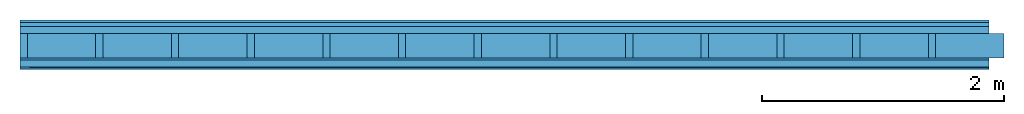
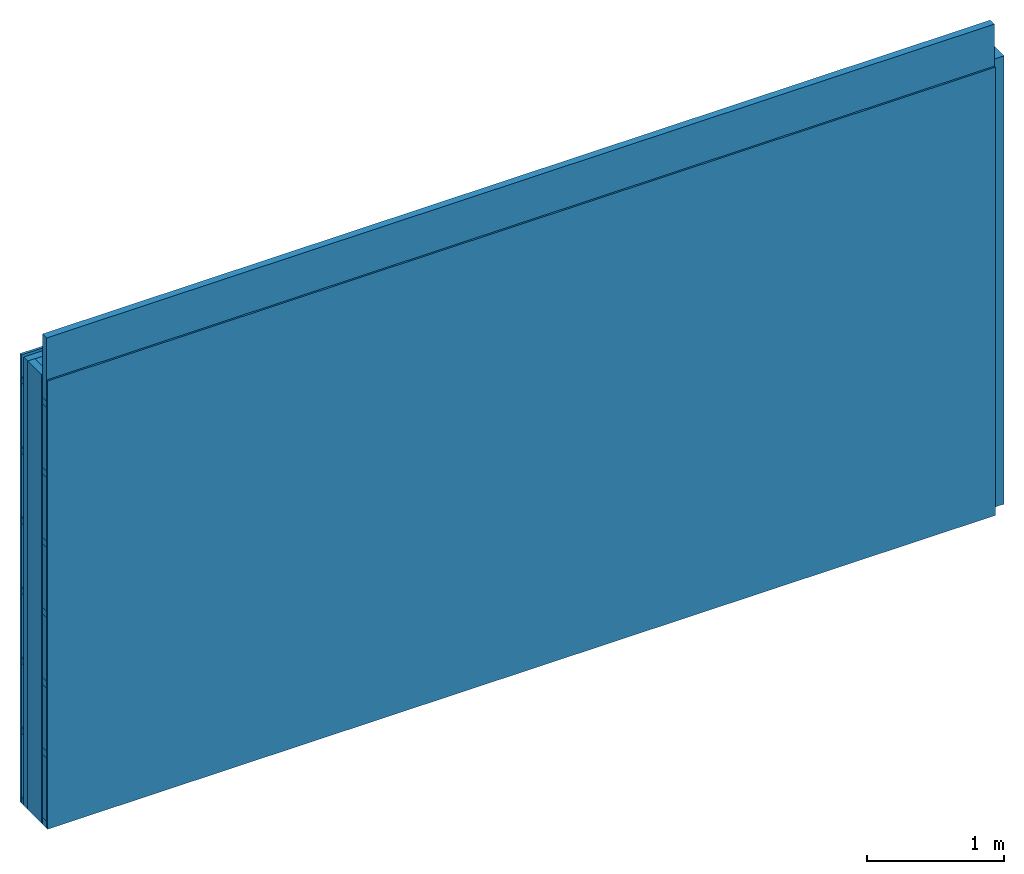
# One storey: 5 members, 4 plates, 1 element without a shape of its own.
"""IFC4 building model written with IfcOpenShell, lengths in metres."""

from ifc_helpers import new_model, si_unit, derived_unit, direction, frame, frame_2d, origin, origin_with_axes, place, context, project, spatial, rectangle, extrude, material, layer, layer_set, type_object, element, aggregate, save


model = new_model("IFC4")

# Units and contexts
plan_context = context("Plan", 3, precision=1e-05, world=origin(), true_north=direction((0.0, 1.0)))
model_context = context("Model", 3, precision=1e-05, world=origin(), true_north=direction((0.0, 1.0)))
ifc_project = project(units=[si_unit("LENGTHUNIT", "METRE"), derived_unit("SOUNDPRESSUREUNIT", [(si_unit("PRESSUREUNIT", "PASCAL", prefix="MICRO"), 0)]), si_unit("ENERGYUNIT", "JOULE", prefix="MEGA"), si_unit("MASSUNIT", "GRAM", prefix="KILO"), derived_unit("THERMALTRANSMITTANCEUNIT", [(si_unit("POWERUNIT", "WATT"), 1), (si_unit("AREAUNIT", "SQUARE_METRE"), -1), (si_unit("THERMODYNAMICTEMPERATUREUNIT", "KELVIN"), -1)]), derived_unit("AREADENSITYUNIT", [(si_unit("MASSUNIT", "GRAM", prefix="KILO"), 1), (si_unit("AREAUNIT", "SQUARE_METRE"), -1)]), derived_unit("USERDEFINED", [(si_unit("ENERGYUNIT", "JOULE", prefix="MEGA"), 1), (si_unit("AREAUNIT", "SQUARE_METRE"), -1)])], contexts=[plan_context, model_context])

# Site, building, storey
site = spatial("IfcSite", under=ifc_project)
building_placement = place(None, origin())
building = spatial("IfcBuilding", under=site, at=building_placement)
storey_placement = place(building_placement, origin())
storey = spatial("IfcBuildingStorey", under=building, at=storey_placement)

# Wall, members, plates
ifc_material_1 = material(Name="Wood cladding horizontal, closed")
ifc_layer_1 = layer(ifc_material_1, 0.022, Name="Cover 1st layer")
ifc_layer_2 = layer(None, 0.03, Name="Battens / profiles (ventilation)")
ifc_material_2 = material(Category="10.009")
ifc_layer_3 = layer(ifc_material_2, 0.06, Name="outside 2nd layer")
ifc_material_3 = material(Name="of the art")
ifc_layer_4 = layer(ifc_material_3, 0.0, Name="Bond")
ifc_layer_5 = layer(None, 0.2, Name="Support")
ifc_layer_6 = layer(ifc_material_3, 0.0, Name="Bond")
ifc_material_4 = material(Category="07.013")
ifc_layer_7 = layer(ifc_material_4, 0.018, Name="1st layer")
ifc_layer_8 = layer(None, 0.06, Name="Battens / profiles")
ifc_material_5 = material(Category="03.007")
ifc_layer_9 = layer(ifc_material_5, 0.015, Name="Covering 1st layer")
ifc_material_6 = material(Name="Glued joints")
ifc_layer_10 = layer(ifc_material_6, 0.0, Name="Surface")
ifc_layer_set = layer_set([ifc_layer_1, ifc_layer_2, ifc_layer_3, ifc_layer_4, ifc_layer_5, ifc_layer_6, ifc_layer_7, ifc_layer_8, ifc_layer_9, ifc_layer_10])
wall_type = type_object("IfcWallType", Name="D0255", PredefinedType="NOTDEFINED", material=ifc_layer_set)
wall_placement = place(None, frame((0.0, 0.0, 0.0), z_axis=(0.0, -1.0, 0.0), x_axis=(1.0, 0.0, 0.0)))
wall = element("IfcWall", 1, at=wall_placement, inside=storey, type_object=wall_type, material=ifc_layer_set, Name="Wall #1")
ifc_material_7 = material()
member_1_placement = place(wall_placement, origin())
member_1 = element("IfcMember", 2, at=member_1_placement, material=ifc_material_7, Name="Battens / profiles (ventilation)", context=plan_context, shape_type="SweptSolid", body=[
    extrude(rectangle(XDim=0.05, YDim=0.03, at=frame_2d((0.025, 0.015), x_axis=(1.0, 0.0))), frame((0.0, 0.0, 0.022), z_axis=(1.0, 0.0, 0.0), x_axis=(0.0, 1.0, 0.0)), (0.0, 0.0, 1.0), 8.0),
    extrude(rectangle(XDim=0.05, YDim=0.03, at=frame_2d((0.025, 0.015), x_axis=(1.0, 0.0))), frame((0.0, 0.625, 0.022), z_axis=(1.0, 0.0, 0.0), x_axis=(0.0, 1.0, 0.0)), (0.0, 0.0, 1.0), 8.0),
    extrude(rectangle(XDim=0.05, YDim=0.03, at=frame_2d((0.025, 0.015), x_axis=(1.0, 0.0))), frame((0.0, 1.25, 0.022), z_axis=(1.0, 0.0, 0.0), x_axis=(0.0, 1.0, 0.0)), (0.0, 0.0, 1.0), 8.0),
    extrude(rectangle(XDim=0.05, YDim=0.03, at=frame_2d((0.025, 0.015), x_axis=(1.0, 0.0))), frame((0.0, 1.875, 0.022), z_axis=(1.0, 0.0, 0.0), x_axis=(0.0, 1.0, 0.0)), (0.0, 0.0, 1.0), 8.0),
    extrude(rectangle(XDim=0.05, YDim=0.03, at=frame_2d((0.025, 0.015), x_axis=(1.0, 0.0))), frame((0.0, 2.5, 0.022), z_axis=(1.0, 0.0, 0.0), x_axis=(0.0, 1.0, 0.0)), (0.0, 0.0, 1.0), 8.0),
    extrude(rectangle(XDim=0.05, YDim=0.03, at=frame_2d((0.025, 0.015), x_axis=(1.0, 0.0))), frame((0.0, 3.125, 0.022), z_axis=(1.0, 0.0, 0.0), x_axis=(0.0, 1.0, 0.0)), (0.0, 0.0, 1.0), 8.0),
    extrude(rectangle(XDim=0.05, YDim=0.03, at=frame_2d((0.025, 0.015), x_axis=(1.0, 0.0))), frame((0.0, 3.75, 0.022), z_axis=(1.0, 0.0, 0.0), x_axis=(0.0, 1.0, 0.0)), (0.0, 0.0, 1.0), 8.0),
])
ifc_material_8 = material()
member_2_placement = place(wall_placement, origin())
member_2 = element("IfcMember", 3, at=member_2_placement, material=ifc_material_8, Name="Support", context=plan_context, shape_type="SweptSolid", body=[
    extrude(rectangle(XDim=0.06, YDim=0.2, at=frame_2d((0.03, 0.1), x_axis=(1.0, 0.0))), frame((0.0, 4.0, 0.112), z_axis=(0.0, -1.0, 0.0), x_axis=(1.0, 0.0, 0.0)), (0.0, 0.0, 1.0), 4.0),
    extrude(rectangle(XDim=0.06, YDim=0.2, at=frame_2d((0.03, 0.1), x_axis=(1.0, 0.0))), frame((0.625, 4.0, 0.112), z_axis=(0.0, -1.0, 0.0), x_axis=(1.0, 0.0, 0.0)), (0.0, 0.0, 1.0), 4.0),
    extrude(rectangle(XDim=0.06, YDim=0.2, at=frame_2d((0.03, 0.1), x_axis=(1.0, 0.0))), frame((1.25, 4.0, 0.112), z_axis=(0.0, -1.0, 0.0), x_axis=(1.0, 0.0, 0.0)), (0.0, 0.0, 1.0), 4.0),
    extrude(rectangle(XDim=0.06, YDim=0.2, at=frame_2d((0.03, 0.1), x_axis=(1.0, 0.0))), frame((1.875, 4.0, 0.112), z_axis=(0.0, -1.0, 0.0), x_axis=(1.0, 0.0, 0.0)), (0.0, 0.0, 1.0), 4.0),
    extrude(rectangle(XDim=0.06, YDim=0.2, at=frame_2d((0.03, 0.1), x_axis=(1.0, 0.0))), frame((2.5, 4.0, 0.112), z_axis=(0.0, -1.0, 0.0), x_axis=(1.0, 0.0, 0.0)), (0.0, 0.0, 1.0), 4.0),
    extrude(rectangle(XDim=0.06, YDim=0.2, at=frame_2d((0.03, 0.1), x_axis=(1.0, 0.0))), frame((3.125, 4.0, 0.112), z_axis=(0.0, -1.0, 0.0), x_axis=(1.0, 0.0, 0.0)), (0.0, 0.0, 1.0), 4.0),
    extrude(rectangle(XDim=0.06, YDim=0.2, at=frame_2d((0.03, 0.1), x_axis=(1.0, 0.0))), frame((3.75, 4.0, 0.112), z_axis=(0.0, -1.0, 0.0), x_axis=(1.0, 0.0, 0.0)), (0.0, 0.0, 1.0), 4.0),
    extrude(rectangle(XDim=0.06, YDim=0.2, at=frame_2d((0.03, 0.1), x_axis=(1.0, 0.0))), frame((4.375, 4.0, 0.112), z_axis=(0.0, -1.0, 0.0), x_axis=(1.0, 0.0, 0.0)), (0.0, 0.0, 1.0), 4.0),
    extrude(rectangle(XDim=0.06, YDim=0.2, at=frame_2d((0.03, 0.1), x_axis=(1.0, 0.0))), frame((5.0, 4.0, 0.112), z_axis=(0.0, -1.0, 0.0), x_axis=(1.0, 0.0, 0.0)), (0.0, 0.0, 1.0), 4.0),
    extrude(rectangle(XDim=0.06, YDim=0.2, at=frame_2d((0.03, 0.1), x_axis=(1.0, 0.0))), frame((5.625, 4.0, 0.112), z_axis=(0.0, -1.0, 0.0), x_axis=(1.0, 0.0, 0.0)), (0.0, 0.0, 1.0), 4.0),
    extrude(rectangle(XDim=0.06, YDim=0.2, at=frame_2d((0.03, 0.1), x_axis=(1.0, 0.0))), frame((6.25, 4.0, 0.112), z_axis=(0.0, -1.0, 0.0), x_axis=(1.0, 0.0, 0.0)), (0.0, 0.0, 1.0), 4.0),
    extrude(rectangle(XDim=0.06, YDim=0.2, at=frame_2d((0.03, 0.1), x_axis=(1.0, 0.0))), frame((6.875, 4.0, 0.112), z_axis=(0.0, -1.0, 0.0), x_axis=(1.0, 0.0, 0.0)), (0.0, 0.0, 1.0), 4.0),
    extrude(rectangle(XDim=0.06, YDim=0.2, at=frame_2d((0.03, 0.1), x_axis=(1.0, 0.0))), frame((7.5, 4.0, 0.112), z_axis=(0.0, -1.0, 0.0), x_axis=(1.0, 0.0, 0.0)), (0.0, 0.0, 1.0), 4.0),
])
ifc_material_9 = material()
member_3_placement = place(wall_placement, origin())
member_3 = element("IfcMember", 4, at=member_3_placement, material=ifc_material_9, Name="Cavity", context=plan_context, shape_type="SweptSolid", body=[
    extrude(rectangle(XDim=0.565, YDim=0.2, at=frame_2d((0.2825, 0.1), x_axis=(1.0, 0.0))), frame((0.06, 4.0, 0.112), z_axis=(0.0, -1.0, 0.0), x_axis=(1.0, 0.0, 0.0)), (0.0, 0.0, 1.0), 4.0),
    extrude(rectangle(XDim=0.565, YDim=0.2, at=frame_2d((0.2825, 0.1), x_axis=(1.0, 0.0))), frame((0.685, 4.0, 0.112), z_axis=(0.0, -1.0, 0.0), x_axis=(1.0, 0.0, 0.0)), (0.0, 0.0, 1.0), 4.0),
    extrude(rectangle(XDim=0.565, YDim=0.2, at=frame_2d((0.2825, 0.1), x_axis=(1.0, 0.0))), frame((1.31, 4.0, 0.112), z_axis=(0.0, -1.0, 0.0), x_axis=(1.0, 0.0, 0.0)), (0.0, 0.0, 1.0), 4.0),
    extrude(rectangle(XDim=0.565, YDim=0.2, at=frame_2d((0.2825, 0.1), x_axis=(1.0, 0.0))), frame((1.935, 4.0, 0.112), z_axis=(0.0, -1.0, 0.0), x_axis=(1.0, 0.0, 0.0)), (0.0, 0.0, 1.0), 4.0),
    extrude(rectangle(XDim=0.565, YDim=0.2, at=frame_2d((0.2825, 0.1), x_axis=(1.0, 0.0))), frame((2.56, 4.0, 0.112), z_axis=(0.0, -1.0, 0.0), x_axis=(1.0, 0.0, 0.0)), (0.0, 0.0, 1.0), 4.0),
    extrude(rectangle(XDim=0.565, YDim=0.2, at=frame_2d((0.2825, 0.1), x_axis=(1.0, 0.0))), frame((3.185, 4.0, 0.112), z_axis=(0.0, -1.0, 0.0), x_axis=(1.0, 0.0, 0.0)), (0.0, 0.0, 1.0), 4.0),
    extrude(rectangle(XDim=0.565, YDim=0.2, at=frame_2d((0.2825, 0.1), x_axis=(1.0, 0.0))), frame((3.81, 4.0, 0.112), z_axis=(0.0, -1.0, 0.0), x_axis=(1.0, 0.0, 0.0)), (0.0, 0.0, 1.0), 4.0),
    extrude(rectangle(XDim=0.565, YDim=0.2, at=frame_2d((0.2825, 0.1), x_axis=(1.0, 0.0))), frame((4.435, 4.0, 0.112), z_axis=(0.0, -1.0, 0.0), x_axis=(1.0, 0.0, 0.0)), (0.0, 0.0, 1.0), 4.0),
    extrude(rectangle(XDim=0.565, YDim=0.2, at=frame_2d((0.2825, 0.1), x_axis=(1.0, 0.0))), frame((5.06, 4.0, 0.112), z_axis=(0.0, -1.0, 0.0), x_axis=(1.0, 0.0, 0.0)), (0.0, 0.0, 1.0), 4.0),
    extrude(rectangle(XDim=0.565, YDim=0.2, at=frame_2d((0.2825, 0.1), x_axis=(1.0, 0.0))), frame((5.685, 4.0, 0.112), z_axis=(0.0, -1.0, 0.0), x_axis=(1.0, 0.0, 0.0)), (0.0, 0.0, 1.0), 4.0),
    extrude(rectangle(XDim=0.565, YDim=0.2, at=frame_2d((0.2825, 0.1), x_axis=(1.0, 0.0))), frame((6.31, 4.0, 0.112), z_axis=(0.0, -1.0, 0.0), x_axis=(1.0, 0.0, 0.0)), (0.0, 0.0, 1.0), 4.0),
    extrude(rectangle(XDim=0.565, YDim=0.2, at=frame_2d((0.2825, 0.1), x_axis=(1.0, 0.0))), frame((6.935, 4.0, 0.112), z_axis=(0.0, -1.0, 0.0), x_axis=(1.0, 0.0, 0.0)), (0.0, 0.0, 1.0), 4.0),
    extrude(rectangle(XDim=0.565, YDim=0.2, at=frame_2d((0.2825, 0.1), x_axis=(1.0, 0.0))), frame((7.56, 4.0, 0.112), z_axis=(0.0, -1.0, 0.0), x_axis=(1.0, 0.0, 0.0)), (0.0, 0.0, 1.0), 4.0),
])
ifc_material_10 = material()
member_4_placement = place(wall_placement, origin())
member_4 = element("IfcMember", 5, at=member_4_placement, material=ifc_material_10, Name="Battens / profiles", context=plan_context, shape_type="SweptSolid", body=[
    extrude(rectangle(XDim=0.06, YDim=0.06, at=frame_2d((0.03, 0.03), x_axis=(1.0, 0.0))), frame((0.0, 0.0, 0.33), z_axis=(1.0, 0.0, 0.0), x_axis=(0.0, 1.0, 0.0)), (0.0, 0.0, 1.0), 8.0),
    extrude(rectangle(XDim=0.06, YDim=0.06, at=frame_2d((0.03, 0.03), x_axis=(1.0, 0.0))), frame((0.0, 0.625, 0.33), z_axis=(1.0, 0.0, 0.0), x_axis=(0.0, 1.0, 0.0)), (0.0, 0.0, 1.0), 8.0),
    extrude(rectangle(XDim=0.06, YDim=0.06, at=frame_2d((0.03, 0.03), x_axis=(1.0, 0.0))), frame((0.0, 1.25, 0.33), z_axis=(1.0, 0.0, 0.0), x_axis=(0.0, 1.0, 0.0)), (0.0, 0.0, 1.0), 8.0),
    extrude(rectangle(XDim=0.06, YDim=0.06, at=frame_2d((0.03, 0.03), x_axis=(1.0, 0.0))), frame((0.0, 1.875, 0.33), z_axis=(1.0, 0.0, 0.0), x_axis=(0.0, 1.0, 0.0)), (0.0, 0.0, 1.0), 8.0),
    extrude(rectangle(XDim=0.06, YDim=0.06, at=frame_2d((0.03, 0.03), x_axis=(1.0, 0.0))), frame((0.0, 2.5, 0.33), z_axis=(1.0, 0.0, 0.0), x_axis=(0.0, 1.0, 0.0)), (0.0, 0.0, 1.0), 8.0),
    extrude(rectangle(XDim=0.06, YDim=0.06, at=frame_2d((0.03, 0.03), x_axis=(1.0, 0.0))), frame((0.0, 3.125, 0.33), z_axis=(1.0, 0.0, 0.0), x_axis=(0.0, 1.0, 0.0)), (0.0, 0.0, 1.0), 8.0),
    extrude(rectangle(XDim=0.06, YDim=0.06, at=frame_2d((0.03, 0.03), x_axis=(1.0, 0.0))), frame((0.0, 3.75, 0.33), z_axis=(1.0, 0.0, 0.0), x_axis=(0.0, 1.0, 0.0)), (0.0, 0.0, 1.0), 8.0),
])
member_5_placement = place(wall_placement, origin())
member_5 = element("IfcMember", 6, at=member_5_placement, material=ifc_material_9, Name="Cavity", context=plan_context, shape_type="SweptSolid", body=[
    extrude(rectangle(XDim=0.565, YDim=0.06, at=frame_2d((0.2825, 0.03), x_axis=(1.0, 0.0))), frame((0.0, 0.06, 0.33), z_axis=(1.0, 0.0, 0.0), x_axis=(0.0, 1.0, 0.0)), (0.0, 0.0, 1.0), 8.0),
    extrude(rectangle(XDim=0.565, YDim=0.06, at=frame_2d((0.2825, 0.03), x_axis=(1.0, 0.0))), frame((0.0, 0.685, 0.33), z_axis=(1.0, 0.0, 0.0), x_axis=(0.0, 1.0, 0.0)), (0.0, 0.0, 1.0), 8.0),
    extrude(rectangle(XDim=0.565, YDim=0.06, at=frame_2d((0.2825, 0.03), x_axis=(1.0, 0.0))), frame((0.0, 1.31, 0.33), z_axis=(1.0, 0.0, 0.0), x_axis=(0.0, 1.0, 0.0)), (0.0, 0.0, 1.0), 8.0),
    extrude(rectangle(XDim=0.565, YDim=0.06, at=frame_2d((0.2825, 0.03), x_axis=(1.0, 0.0))), frame((0.0, 1.935, 0.33), z_axis=(1.0, 0.0, 0.0), x_axis=(0.0, 1.0, 0.0)), (0.0, 0.0, 1.0), 8.0),
    extrude(rectangle(XDim=0.565, YDim=0.06, at=frame_2d((0.2825, 0.03), x_axis=(1.0, 0.0))), frame((0.0, 2.56, 0.33), z_axis=(1.0, 0.0, 0.0), x_axis=(0.0, 1.0, 0.0)), (0.0, 0.0, 1.0), 8.0),
    extrude(rectangle(XDim=0.565, YDim=0.06, at=frame_2d((0.2825, 0.03), x_axis=(1.0, 0.0))), frame((0.0, 3.185, 0.33), z_axis=(1.0, 0.0, 0.0), x_axis=(0.0, 1.0, 0.0)), (0.0, 0.0, 1.0), 8.0),
    extrude(rectangle(XDim=0.565, YDim=0.06, at=frame_2d((0.2825, 0.03), x_axis=(1.0, 0.0))), frame((0.0, 3.81, 0.33), z_axis=(1.0, 0.0, 0.0), x_axis=(0.0, 1.0, 0.0)), (0.0, 0.0, 1.0), 8.0),
])
plate_1_placement = place(wall_placement, origin())
plate_1 = element("IfcPlate", 7, at=plate_1_placement, material=ifc_material_1, Name="Cover 1st layer", context=plan_context, shape_type="SweptSolid", body=[
    extrude(rectangle(XDim=8.0, YDim=4.0, at=frame_2d((4.0, 2.0), x_axis=(1.0, 0.0))), origin_with_axes(), (0.0, 0.0, 1.0), 0.022),
])
plate_2_placement = place(wall_placement, origin())
plate_2 = element("IfcPlate", 8, at=plate_2_placement, material=ifc_material_2, Name="outside 2nd layer", context=plan_context, shape_type="SweptSolid", body=[
    extrude(rectangle(XDim=8.0, YDim=4.0, at=frame_2d((4.0, 2.0), x_axis=(1.0, 0.0))), frame((0.0, 0.0, 0.052), z_axis=(0.0, 0.0, 1.0), x_axis=(1.0, 0.0, 0.0)), (0.0, 0.0, 1.0), 0.06),
])
plate_3_placement = place(wall_placement, origin())
plate_3 = element("IfcPlate", 9, at=plate_3_placement, material=ifc_material_4, Name="1st layer", context=plan_context, shape_type="SweptSolid", body=[
    extrude(rectangle(XDim=8.0, YDim=4.0, at=frame_2d((4.0, 2.0), x_axis=(1.0, 0.0))), frame((0.0, 0.0, 0.312), z_axis=(0.0, 0.0, 1.0), x_axis=(1.0, 0.0, 0.0)), (0.0, 0.0, 1.0), 0.018),
])
plate_4_placement = place(wall_placement, origin())
plate_4 = element("IfcPlate", 10, at=plate_4_placement, material=ifc_material_5, Name="Covering 1st layer", context=plan_context, shape_type="SweptSolid", body=[
    extrude(rectangle(XDim=8.0, YDim=4.0, at=frame_2d((4.0, 2.0), x_axis=(1.0, 0.0))), frame((0.0, 0.0, 0.39), z_axis=(0.0, 0.0, 1.0), x_axis=(1.0, 0.0, 0.0)), (0.0, 0.0, 1.0), 0.015),
])
aggregate(wall, [plate_1, member_1, plate_2, member_2, member_3, plate_3, member_4, member_5, plate_4])

save(model, "model.ifc")
